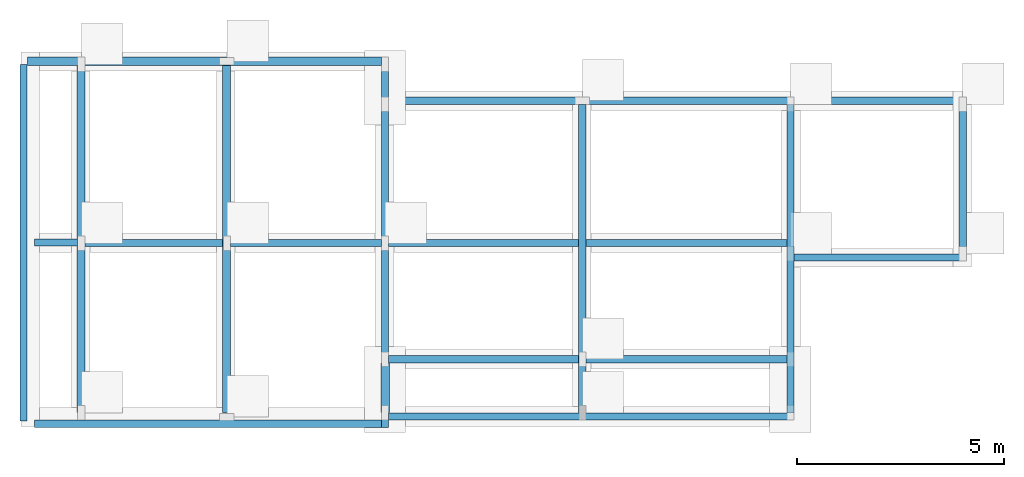
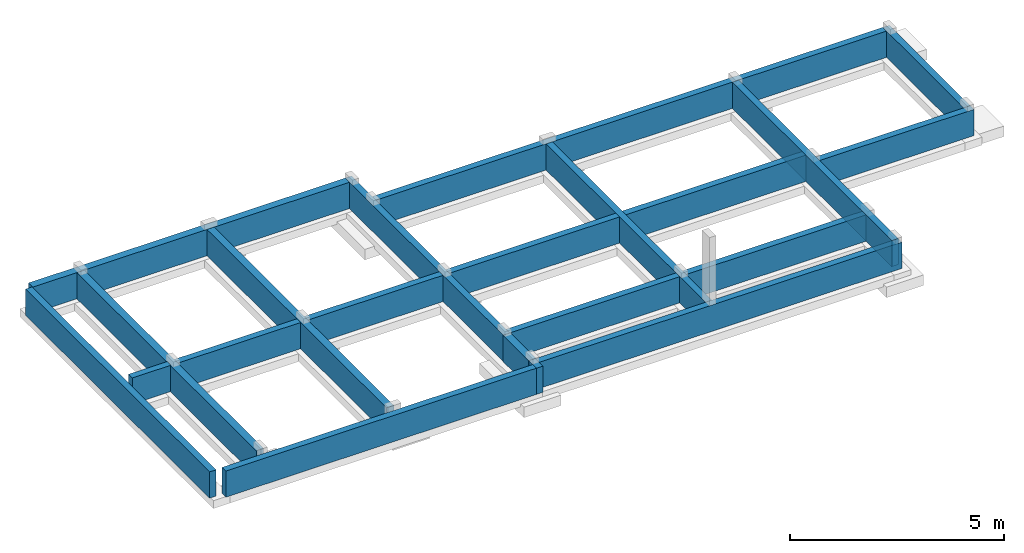
# One storey, part 2 of 2: 18 walls.
"""IFC4 building model written with IfcOpenShell, lengths in millimetres."""

import ifcopenshell
import ifcopenshell.guid

model = None  # the IFC model being written
_history = None  # IfcOwnerHistory: only IFC2X3 demands one
_inside = {}  # id of a spatial element -> (the spatial element, [elements in it])
_under = {}  # id of a project, library or spatial element -> (it, [spatial elements below it])
_declared = {}  # id of a project -> (the project, [libraries it declares])
_typed = {}  # id of a type object -> (the type object, [elements of that type])
_made_of = {}  # id of a material, layer set ... -> (it, [elements and type objects made of it])


def new_model(schema):
    """Start an empty IFC model of exactly this schema.

    Asked for "IFC4X3", IfcOpenShell would pick the latest addendum, in which some entities
    have other attributes; the version numbers below select the first issue.
    IFC2X3 requires an IfcOwnerHistory on every rooted entity: one is made here for all.
    """
    global model, _history
    if schema == "IFC4X3":
        model = ifcopenshell.file(schema_version=(4, 3, 0, 0))
    else:
        model = ifcopenshell.file(schema=schema)
    _inside.clear()
    _under.clear()
    _declared.clear()
    _typed.clear()
    _made_of.clear()
    _history = None
    if model.schema == "IFC2X3":
        org = make("IfcOrganization", Name="unknown")
        user = make(
            "IfcPersonAndOrganization",
            ThePerson=make("IfcPerson", FamilyName="unknown"),
            TheOrganization=org,
        )
        app = make(
            "IfcApplication",
            ApplicationDeveloper=org,
            Version="unknown",
            ApplicationFullName="unknown",
            ApplicationIdentifier="unknown",
        )
        _history = make(
            "IfcOwnerHistory",
            OwningUser=user,
            OwningApplication=app,
            ChangeAction="ADDED",
            CreationDate=0,
        )
    return model


def make(cls, **values):
    """One entity of the class cls with the attributes given. An attribute that is None is left unset."""
    return model.create_entity(
        cls, **{name: value for name, value in values.items() if value is not None}
    )


def entity(cls, *values):
    """Any entity or typed value of the class cls, its attributes in the order of the schema. None: left unset."""
    e = model.create_entity(cls)
    for i, value in enumerate(values):
        if value is not None:
            e[i] = value
    return e


def rooted(cls, **values):
    """An entity with a GlobalId (a new one), such as an element, a storey or a relation."""
    return make(cls, GlobalId=ifcopenshell.guid.new(), OwnerHistory=_history, **values)


def si_unit(unit_type, name, prefix=None):
    """IfcSIUnit, for example si_unit("LENGTHUNIT", "METRE", prefix="MILLI")."""
    return make("IfcSIUnit", UnitType=unit_type, Prefix=prefix, Name=name)


def converted_unit(unit_type, name, factor, base, dimensions=None, offset=None):
    """IfcConversionBasedUnit, such as the inch: factor (a typed value) times the base unit."""
    return make(
        "IfcConversionBasedUnit"
        if offset is None
        else "IfcConversionBasedUnitWithOffset",
        ConversionOffset=offset,
        Dimensions=None
        if dimensions is None
        else entity("IfcDimensionalExponents", *dimensions),
        UnitType=unit_type,
        Name=name,
        ConversionFactor=make(
            "IfcMeasureWithUnit", ValueComponent=factor, UnitComponent=base
        ),
    )


def assignment(units):
    """IfcUnitAssignment: the units of a project."""
    return None if units is None else make("IfcUnitAssignment", Units=units)


def point(xyz):
    """IfcCartesianPoint."""
    return None if xyz is None else make("IfcCartesianPoint", Coordinates=xyz)


def direction(xyz):
    """IfcDirection."""
    return None if xyz is None else make("IfcDirection", DirectionRatios=xyz)


def frame(location, z_axis=None, x_axis=None):
    """IfcAxis2Placement3D, a coordinate frame: its origin and axes. An axis left out is left unset."""
    return make(
        "IfcAxis2Placement3D",
        Location=point(location),
        Axis=direction(z_axis),
        RefDirection=direction(x_axis),
    )


def frame_2d(location, x_axis=None):
    """IfcAxis2Placement2D, a coordinate frame in the plane: its origin and x axis."""
    return make(
        "IfcAxis2Placement2D", Location=point(location), RefDirection=direction(x_axis)
    )


def origin_with_axes():
    """The frame at (0, 0, 0) with the z axis (0, 0, 1) and the x axis (1, 0, 0) written out."""
    return frame((0.0, 0.0, 0.0), z_axis=(0.0, 0.0, 1.0), x_axis=(1.0, 0.0, 0.0))


def origin_2d_with_axis():
    """The frame at (0, 0) in the plane with the x axis (1, 0) written out."""
    return frame_2d((0.0, 0.0), x_axis=(1.0, 0.0))


def place(relative_to, where):
    """IfcLocalPlacement: puts the frame where relative to a parent placement (None: the world)."""
    return make(
        "IfcLocalPlacement", PlacementRelTo=relative_to, RelativePlacement=where
    )


def context(
    kind, dimensions, precision=None, world=None, true_north=None, identifier=None
):
    """IfcGeometricRepresentationContext, for example the 3D "Model" context."""
    return make(
        "IfcGeometricRepresentationContext",
        ContextIdentifier=identifier,
        ContextType=kind,
        CoordinateSpaceDimension=dimensions,
        Precision=precision,
        WorldCoordinateSystem=world,
        TrueNorth=true_north,
    )


def subcontext(parent, identifier, kind, view, scale=None):
    """IfcGeometricRepresentationSubContext, for example "Body" below "Model"."""
    return make(
        "IfcGeometricRepresentationSubContext",
        ContextIdentifier=identifier,
        ContextType=kind,
        ParentContext=parent,
        TargetScale=scale,
        TargetView=view,
    )


def project(units=None, contexts=None):
    """IfcProject with its units and contexts."""
    return rooted(
        "IfcProject",
        Name="project",
        RepresentationContexts=contexts,
        UnitsInContext=assignment(units),
    )


def spatial(cls, under=None, at=None, **own):
    """A site, building, storey or space (cls), placed at a placement, below another one or the project."""
    s = rooted(cls, ObjectPlacement=at, **own)
    if under is not None:
        _under.setdefault(under.id(), (under, []))[1].append(s)
    return s


def point_list(points):
    """IfcCartesianPointList2D or 3D."""
    cls = (
        "IfcCartesianPointList2D" if len(points[0]) == 2 else "IfcCartesianPointList3D"
    )
    return make(cls, CoordList=points)


def indexed_curve(points, segments=None, self_intersect=None):
    """IfcIndexedPolyCurve: lines and arcs through numbered points (the first is 1)."""
    return make(
        "IfcIndexedPolyCurve",
        Points=point_list(points),
        Segments=segments,
        SelfIntersect=self_intersect,
    )


def outline(outer, holes=None, kind="AREA"):
    """IfcArbitraryClosedProfileDef: a profile drawn as a closed curve; with holes, ...WithVoids."""
    if holes is None:
        return make("IfcArbitraryClosedProfileDef", ProfileType=kind, OuterCurve=outer)
    return make(
        "IfcArbitraryProfileDefWithVoids",
        ProfileType=kind,
        OuterCurve=outer,
        InnerCurves=holes,
    )


def extrude(swept, where, along, depth):
    """IfcExtrudedAreaSolid: the profile swept, set in the frame where, extruded along a direction by depth."""
    return make(
        "IfcExtrudedAreaSolid",
        SweptArea=swept,
        Position=where,
        ExtrudedDirection=direction(along),
        Depth=depth,
    )


def shape(context_of_items, identifier, shape_type, items):
    """IfcShapeRepresentation: the items that make up one representation, for example the "Body"."""
    return make(
        "IfcShapeRepresentation",
        ContextOfItems=context_of_items,
        RepresentationIdentifier=identifier,
        RepresentationType=shape_type,
        Items=items,
    )


def material(Name=None, Category=None):
    """IfcMaterial."""
    return make("IfcMaterial", Name=Name, Category=Category)


def layer(
    of_material, thickness, ventilated=None, Name=None, Category=None, Priority=None
):
    """IfcMaterialLayer: one layer of a wall or slab, of a material (None: an air gap)."""
    return make(
        "IfcMaterialLayer",
        Material=of_material,
        LayerThickness=thickness,
        IsVentilated=ventilated,
        Name=Name,
        Category=Category,
        Priority=Priority,
    )


def layer_set(layers, Name=None):
    """IfcMaterialLayerSet."""
    return make("IfcMaterialLayerSet", MaterialLayers=layers, LayerSetName=Name)


def layer_usage(for_layer_set, set_direction, sense, offset, extent=None):
    """IfcMaterialLayerSetUsage: how a layer set lies in its element."""
    return make(
        "IfcMaterialLayerSetUsage",
        ForLayerSet=for_layer_set,
        LayerSetDirection=set_direction,
        DirectionSense=sense,
        OffsetFromReferenceLine=offset,
        ReferenceExtent=extent,
    )


def made_of(thing, what):
    """Note that an element or type object is made of a material, layer set ...; save() writes the relation."""
    if what is not None:
        _made_of.setdefault(what.id(), (what, []))[1].append(thing)
    return thing


def type_object(cls, material=None, **own):
    """A type object (cls), such as IfcWallType, which elements share."""
    return made_of(rooted(cls, **own), material)


def element(
    cls,
    number,
    at=None,
    inside=None,
    cuts=None,
    type_object=None,
    material=None,
    context=None,
    identifier="Body",
    shape_type=None,
    held_by="IfcProductDefinitionShape",
    body=None,
    shapes=None,
    **own,
):
    """One element of the class cls, such as IfcWall. Its Tag is "e" and its number.

    at: its placement. inside: the storey or other place that contains it. cuts: it is an
    opening in that element (IfcRelVoidsElement). A single representation is given by context,
    identifier, shape_type and body (its items); several are given by shapes. held_by: the class
    of the entity that holds the representations. save() writes the other relations.
    """
    e = rooted(cls, Tag="e%d" % number, ObjectPlacement=at, **own)
    if body is not None:
        shapes = [shape(context, identifier, shape_type, body)]
    if shapes is not None:
        e.Representation = make(held_by, Representations=shapes)
    if inside is not None:
        _inside.setdefault(inside.id(), (inside, []))[1].append(e)
    if cuts is not None:
        rooted(
            "IfcRelVoidsElement", RelatingBuildingElement=cuts, RelatedOpeningElement=e
        )
    if type_object is not None:
        _typed.setdefault(type_object.id(), (type_object, []))[1].append(e)
    return made_of(e, material)


def aggregate(whole, parts):
    """IfcRelAggregates: a whole, such as a stair, and the parts it consists of."""
    return rooted("IfcRelAggregates", RelatingObject=whole, RelatedObjects=parts)


def save(model, path):
    """Write the relations noted so far, then the file.

    IfcRelAggregates (storeys below a building ...), IfcRelContainedInSpatialStructure (elements
    in a storey), IfcRelDefinesByType, IfcRelAssociatesMaterial and IfcRelDeclares: one each for
    every whole, place, type object, material and project.
    """
    for whole, parts in _under.values():
        aggregate(whole, parts)
    for where, things in _inside.values():
        rooted(
            "IfcRelContainedInSpatialStructure",
            RelatedElements=things,
            RelatingStructure=where,
        )
    for kind, things in _typed.values():
        rooted("IfcRelDefinesByType", RelatedObjects=things, RelatingType=kind)
    for what, things in _made_of.values():
        rooted("IfcRelAssociatesMaterial", RelatedObjects=things, RelatingMaterial=what)
    for by, libraries in _declared.values():
        rooted("IfcRelDeclares", RelatingContext=by, RelatedDefinitions=libraries)
    model.write(path)


model = new_model("IFC4")

# Units and contexts
model_context = context("Model", 3, precision=1e-05, world=origin_with_axes())
plan_context = context("Plan", 2, precision=1e-05, world=origin_2d_with_axis())
body_context = subcontext(model_context, "Body", "Model", "MODEL_VIEW")
ifc_project = project(units=[si_unit("VOLUMEUNIT", "CUBIC_METRE"), si_unit("LENGTHUNIT", "METRE", prefix="MILLI"), converted_unit("PLANEANGLEUNIT", "degree", entity("IfcReal", 0.0174532925199433), si_unit("PLANEANGLEUNIT", "RADIAN"), dimensions=[0, 0, 0, 0, 0, 0, 0]), si_unit("AREAUNIT", "SQUARE_METRE")], contexts=[model_context, plan_context])

# Site, building, storey
site_placement = place(None, origin_with_axes())
site = spatial("IfcSite", under=ifc_project, at=site_placement)
building_placement = place(site_placement, origin_with_axes())
building = spatial("IfcBuilding", under=site, at=building_placement, Name="Building")
storey_placement = place(building_placement, frame((0.0, 0.0, -900.000035762787), z_axis=(0.0, 0.0, 1.0), x_axis=(1.0, 0.0, 0.0)))
storey = spatial("IfcBuildingStorey", under=building, at=storey_placement, Name="FOUNDATION")

# Walls
ifc_material_1 = material()
ifc_layer_1 = layer(ifc_material_1, 200.0)
ifc_layer_set_1 = layer_set([ifc_layer_1])
ifc_layer_usage_1 = layer_usage(ifc_layer_set_1, "AXIS2", "POSITIVE", 0.0)
wall_type_1 = type_object("IfcWallType", Name="WAL200", PredefinedType="NOTDEFINED", material=ifc_layer_set_1)
wall_1_placement = place(storey_placement, frame((-17331.8939208984, 3824.96094703674, 0.0), z_axis=(0.0, 0.0, 1.0), x_axis=(3.13916473260163e-07, 0.999999999999951, 0.0)))
element("IfcWall", 1, at=wall_1_placement, inside=storey, type_object=wall_type_1, material=ifc_layer_usage_1, Name="WAL200", context=body_context, shape_type="SweptSolid", body=[
    extrude(outline(indexed_curve([(0.0, 0.0), (0.0, 200.0), (8400.00439598353, 200.0), (8400.00439598353, 0.0), (0.0, 0.0)], self_intersect=False)), origin_with_axes(), (0.0, 0.0, 1.0), 750.000059604645),
])
ifc_layer_usage_2 = layer_usage(ifc_layer_set_1, "AXIS2", "POSITIVE", 0.0)
wall_2_placement = place(storey_placement, frame((-10171.9236373901, 5024.95861053467, 0.0), z_axis=(0.0, 0.0, 1.0), x_axis=(-5.2054855359522e-07, -0.999999999999865, 0.0)))
element("IfcWall", 2, at=wall_2_placement, inside=storey, type_object=wall_type_1, material=ifc_layer_usage_2, Name="WAL200", context=body_context, shape_type="SweptSolid", body=[
    extrude(outline(indexed_curve([(0.0, 0.0), (0.0, 200.0), (1199.99982516008, 200.0), (1199.99982516008, 0.0), (0.0, 0.0)], self_intersect=False)), origin_with_axes(), (0.0, 0.0, 1.0), 750.000059604645),
])
ifc_layer_usage_3 = layer_usage(ifc_layer_set_1, "AXIS2", "POSITIVE", 0.0)
wall_3_placement = place(storey_placement, frame((-13814.0277862549, 3824.96047019958, 1.11022302462516e-13), z_axis=(0.0, 0.0, 1.0), x_axis=(3.13916473260163e-07, 0.999999999999951, 0.0)))
element("IfcWall", 3, at=wall_3_placement, inside=storey, type_object=wall_type_1, material=ifc_layer_usage_3, Name="WAL200", context=body_context, shape_type="SweptSolid", body=[
    extrude(outline(indexed_curve([(0.0, 0.0), (0.0, 200.0), (8400.00439598353, 200.0), (8400.00439598353, 0.0), (0.0, 0.0)], self_intersect=False)), origin_with_axes(), (0.0, 0.0, 1.0), 750.000059604645),
])
ifc_material_2 = material(Name="Mortar", Category="Masonry")
ifc_layer_2 = layer(ifc_material_2, 12.5, Name="Mortar Layer", Category="Substrate", Priority=2)
ifc_material_3 = material(Category="Masonry")
ifc_layer_3 = layer(ifc_material_3, 150.0, Name="Layer", Category="Structure", Priority=1)
ifc_layer_4 = layer(ifc_material_2, 12.5, Name="Int. Mortar Layer", Category="Substrate", Priority=2)
ifc_layer_set_2 = layer_set([ifc_layer_2, ifc_layer_3, ifc_layer_4], Name="WALL-SLD-3LYR")
ifc_layer_usage_4 = layer_usage(ifc_layer_set_2, "AXIS2", "POSITIVE", 0.0)
wall_type_2 = type_object("IfcWallType", Name="SLD150", PredefinedType="SOLIDWALL", material=ifc_layer_set_2)
wall_4_placement = place(storey_placement, frame((-10163.9194488525, 12424.9629974365, 1.11022302462516e-13), z_axis=(0.0, 0.0, 1.0), x_axis=(-0.999999999999924, 3.89414367418765e-07, 0.0)))
element("IfcWall", 4, at=wall_4_placement, inside=storey, type_object=wall_type_2, material=ifc_layer_usage_4, Name="WAL200", context=body_context, shape_type="SweptSolid", body=[
    extrude(outline(indexed_curve([(0.0, 0.0), (0.0, 200.0), (8559.971791159, 200.0), (8559.971791159, 0.0), (0.0, 0.0)], self_intersect=False)), origin_with_axes(), (0.0, 0.0, 1.0), 750.000059604645),
])
ifc_layer_usage_5 = layer_usage(ifc_layer_set_2, "AXIS2", "POSITIVE", 0.0)
wall_5_placement = place(storey_placement, frame((-9988.92211914062, 3466.95351600647, 1.11022302462516e-13), z_axis=(0.0, 0.0, 1.0), x_axis=(3.13916473260163e-07, 0.999999999999951, 0.0)))
element("IfcWall", 5, at=wall_5_placement, inside=storey, type_object=wall_type_2, material=ifc_layer_usage_5, Name="SLD150", context=body_context, shape_type="SweptSolid", body=[
    extrude(outline(indexed_curve([(0.0, 0.0), (0.0, 175.0), (8958.00988848067, 175.0), (8958.00988848067, 0.0), (0.0, 0.0)], self_intersect=False)), origin_with_axes(), (0.0, 0.0, 1.0), 750.0),
])
ifc_layer_usage_6 = layer_usage(ifc_layer_set_2, "AXIS2", "POSITIVE", 0.0)
wall_6_placement = place(storey_placement, frame((3809.29946899414, 11457.9629898071, 1.11022302462516e-13), z_axis=(0.0, 0.0, 1.0), x_axis=(-0.999999999999989, 1.50995802528085e-07, 0.0)))
element("IfcWall", 6, at=wall_6_placement, inside=storey, type_object=wall_type_2, material=ifc_layer_usage_6, Name="SLD150", context=body_context, shape_type="SweptSolid", body=[
    extrude(outline(indexed_curve([(0.0, 0.0), (0.0, 175.0), (13798.2197815743, 175.0), (13798.2197815743, 0.0), (0.0, 0.0)], self_intersect=False)), origin_with_axes(), (0.0, 0.0, 1.0), 750.0),
])
ifc_layer_usage_7 = layer_usage(ifc_layer_set_2, "AXIS2", "POSITIVE", 0.0)
wall_7_placement = place(storey_placement, frame((-17331.8920135498, 7841.96519851685, 1.11022302462516e-13), z_axis=(0.0, 0.0, 1.0), x_axis=(0.999999999999886, -4.76837158203071e-07, 0.0)))
element("IfcWall", 7, at=wall_7_placement, inside=storey, type_object=wall_type_2, material=ifc_layer_usage_7, Name="SLD150", context=body_context, shape_type="SweptSolid", body=[
    extrude(outline(indexed_curve([(0.0, 0.0), (0.0, 175.0), (16976.9669619351, 175.0), (16976.9669619351, 0.0), (0.0, 0.0)], self_intersect=False)), origin_with_axes(), (0.0, 0.0, 1.0), 750.0),
])
ifc_layer_usage_8 = layer_usage(ifc_layer_set_2, "AXIS2", "POSITIVE", 0.0)
wall_8_placement = place(storey_placement, frame((-18731.8954467773, 3624.96280670166, 1.11022302462516e-13), z_axis=(0.0, 0.0, 1.0), x_axis=(3.13916473260163e-07, 0.999999999999951, 0.0)))
element("IfcWall", 8, at=wall_8_placement, inside=storey, type_object=wall_type_2, material=ifc_layer_usage_8, Name="SLD150", context=body_context, shape_type="SweptSolid", body=[
    extrude(outline(indexed_curve([(0.0, 0.0), (0.0, 175.0), (8617.0033411874, 175.0), (8617.0033411874, 0.0), (0.0, 0.0)], self_intersect=False)), origin_with_axes(), (0.0, 0.0, 1.0), 750.0),
])
ifc_layer_usage_9 = layer_usage(ifc_layer_set_2, "AXIS2", "POSITIVE", 0.0)
wall_9_placement = place(storey_placement, frame((-17514.892578125, 8024.96337890625, 1.11022302462516e-13), z_axis=(0.0, 0.0, 1.0), x_axis=(-0.999999999999924, 3.89414367418765e-07, 0.0)))
element("IfcWall", 9, at=wall_9_placement, inside=storey, type_object=wall_type_2, material=ifc_layer_usage_9, Name="SLD150", context=body_context, shape_type="SweptSolid", body=[
    extrude(outline(indexed_curve([(0.0, 0.0), (0.0, 175.0), (1042.00362795383, 175.0), (1042.00362795383, 0.0), (0.0, 0.0)], self_intersect=False)), origin_with_axes(), (0.0, 0.0, 1.0), 750.0),
])
ifc_layer_usage_10 = layer_usage(ifc_layer_set_2, "AXIS2", "POSITIVE", 0.0)
wall_10_placement = place(storey_placement, frame((-10163.9223098755, 3641.95346832275, 1.11022302462516e-13), z_axis=(0.0, 0.0, 1.0), x_axis=(-0.999999999999625, 8.66251525621595e-07, 0.0)))
element("IfcWall", 10, at=wall_10_placement, inside=storey, type_object=wall_type_2, material=ifc_layer_usage_10, Name="SLD150", context=body_context, shape_type="SweptSolid", body=[
    extrude(outline(indexed_curve([(0.0, 0.0), (0.0, 175.0), (8392.97378598427, 175.0), (8392.97378598427, 0.0), (0.0, 0.0)], self_intersect=False)), origin_with_axes(), (0.0, 0.0, 1.0), 750.0),
])
ifc_layer_usage_11 = layer_usage(ifc_layer_set_2, "AXIS2", "POSITIVE", 0.0)
wall_11_placement = place(storey_placement, frame((-9988.92211914062, 5024.95861053467, 1.11022302462516e-13), z_axis=(0.0, 0.0, 1.0), x_axis=(0.999999999999822, -5.960464477538e-07, 0.0)))
element("IfcWall", 11, at=wall_11_placement, inside=storey, type_object=wall_type_2, material=ifc_layer_usage_11, Name="SLD150", context=body_context, shape_type="SweptSolid", body=[
    extrude(outline(indexed_curve([(0.0, 0.0), (0.0, 175.0), (9805.66012357236, 175.0), (9805.66012357236, 0.0), (0.0, 0.0)], self_intersect=False)), origin_with_axes(), (0.0, 0.0, 1.0), 750.000059604645),
])
ifc_layer_usage_12 = layer_usage(ifc_layer_set_2, "AXIS2", "POSITIVE", 0.0)
wall_12_placement = place(storey_placement, frame((-358.260631561279, 11282.9637527466, 1.11022302462516e-13), z_axis=(0.0, 0.0, 1.0), x_axis=(-1.62920684942944e-07, -0.999999999999987, 0.0)))
element("IfcWall", 12, at=wall_12_placement, inside=storey, type_object=wall_type_2, material=ifc_layer_usage_12, Name="SLD150", context=body_context, shape_type="SweptSolid", body=[
    extrude(outline(indexed_curve([(0.0, 0.0), (0.0, 175.0), (7466.01543084233, 175.0), (7466.01543084233, 0.0), (0.0, 0.0)], self_intersect=False)), origin_with_axes(), (0.0, 0.0, 1.0), 750.000059604645),
])
ifc_layer_usage_13 = layer_usage(ifc_layer_set_2, "AXIS2", "POSITIVE", 0.0)
wall_13_placement = place(storey_placement, frame((-183.26136469841, 7492.17510223389, 1.11022302462516e-13), z_axis=(0.0, 0.0, 1.0), x_axis=(0.999999999999936, -3.57627868652321e-07, 0.0)))
element("IfcWall", 13, at=wall_13_placement, inside=storey, type_object=wall_type_2, material=ifc_layer_usage_13, Name="SLD150", context=body_context, shape_type="SweptSolid", body=[
    extrude(outline(indexed_curve([(0.0, 0.0), (0.0, 175.0), (4167.55824404787, 175.0), (4167.55824404787, 0.0), (0.0, 0.0)], self_intersect=False)), origin_with_axes(), (0.0, 0.0, 1.0), 750.000059604645),
])
ifc_layer_usage_14 = layer_usage(ifc_layer_set_2, "AXIS2", "POSITIVE", 0.0)
wall_14_placement = place(storey_placement, frame((3984.29679870605, 7667.17386245728, 1.11022302462516e-13), z_axis=(0.0, 0.0, 1.0), x_axis=(6.71544341912371e-07, 0.999999999999775, 0.0)))
element("IfcWall", 14, at=wall_14_placement, inside=storey, type_object=wall_type_2, material=ifc_layer_usage_14, Name="SLD150", context=body_context, shape_type="SweptSolid", body=[
    extrude(outline(indexed_curve([(0.0, 0.0), (0.0, 175.0), (3790.78908692599, 175.0), (3790.78908692599, 0.0), (0.0, 0.0)], self_intersect=False)), origin_with_axes(), (0.0, 0.0, 1.0), 750.000059604645),
])
ifc_layer_usage_15 = layer_usage(ifc_layer_set_2, "AXIS2", "POSITIVE", 0.0)
wall_15_placement = place(storey_placement, frame((-5217.95225143433, 3816.95055961609, 1.11022302462516e-13), z_axis=(0.0, 0.0, 1.0), x_axis=(3.13916473260163e-07, 0.999999999999951, 0.0)))
element("IfcWall", 15, at=wall_15_placement, inside=storey, type_object=wall_type_2, material=ifc_layer_usage_15, Name="SLD150", context=body_context, shape_type="SweptSolid", body=[
    extrude(outline(indexed_curve([(0.0, 0.0), (0.0, 175.0), (7466.01287613457, 175.0), (7466.01287613457, 0.0), (0.0, 0.0)], self_intersect=False)), origin_with_axes(), (0.0, 0.0, 1.0), 750.000059604645),
])
ifc_layer_usage_16 = layer_usage(ifc_layer_set_2, "AXIS2", "POSITIVE", 0.0)
wall_16_placement = place(storey_placement, frame((-9988.92211914062, 3641.9529914856, 1.11022302462516e-13), z_axis=(0.0, 0.0, 1.0), x_axis=(0.999999999999886, -4.76837158203071e-07, 0.0)))
element("IfcWall", 16, at=wall_16_placement, inside=storey, type_object=wall_type_2, material=ifc_layer_usage_16, Name="SLD150", context=body_context, shape_type="SweptSolid", body=[
    extrude(outline(indexed_curve([(0.0, 0.0), (0.0, 175.0), (9805.66012357174, 175.0), (9805.66012357174, 0.0), (0.0, 0.0)], self_intersect=False)), origin_with_axes(), (0.0, 0.0, 1.0), 750.000059604645),
])
ifc_layer_usage_17 = layer_usage(ifc_layer_set_2, "AXIS2", "POSITIVE", 0.0)
wall_17_placement = place(storey_placement, frame((-358.260631561279, 11282.9637527466, 1.11022302462516e-13), z_axis=(0.0, 0.0, 1.0), x_axis=(-1.62920684942944e-07, -0.999999999999987, 0.0)))
element("IfcWall", 17, at=wall_17_placement, inside=storey, type_object=wall_type_2, material=ifc_layer_usage_17, Name="SLD150", context=body_context, shape_type="SweptSolid", body=[
    extrude(outline(indexed_curve([(0.0, 0.0), (0.0, 175.0), (7466.01543084233, 175.0), (7466.01543084233, 0.0), (0.0, 0.0)], self_intersect=False)), origin_with_axes(), (0.0, 0.0, 1.0), 750.000059604645),
])
ifc_layer_usage_18 = layer_usage(ifc_layer_set_2, "AXIS2", "POSITIVE", 0.0)
wall_18_placement = place(storey_placement, frame((-358.260631561279, 11282.9637527466, 1.11022302462516e-13), z_axis=(0.0, 0.0, 1.0), x_axis=(-1.62920684942944e-07, -0.999999999999987, 0.0)))
element("IfcWall", 18, at=wall_18_placement, inside=storey, type_object=wall_type_2, material=ifc_layer_usage_18, Name="SLD150", context=body_context, shape_type="SweptSolid", body=[
    extrude(outline(indexed_curve([(0.0, 0.0), (0.0, 175.0), (7466.01543084233, 175.0), (7466.01543084233, 0.0), (0.0, 0.0)], self_intersect=False)), origin_with_axes(), (0.0, 0.0, 1.0), 750.000059604645),
])

save(model, "model.ifc")
